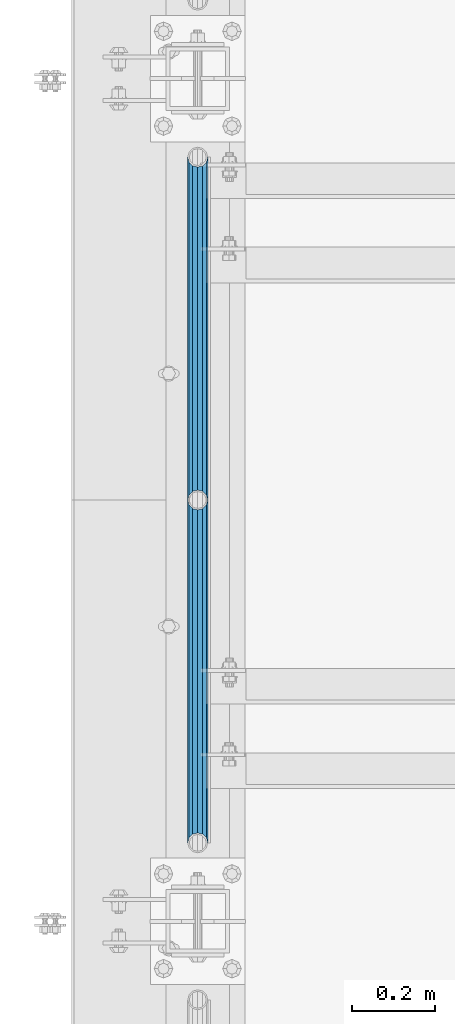
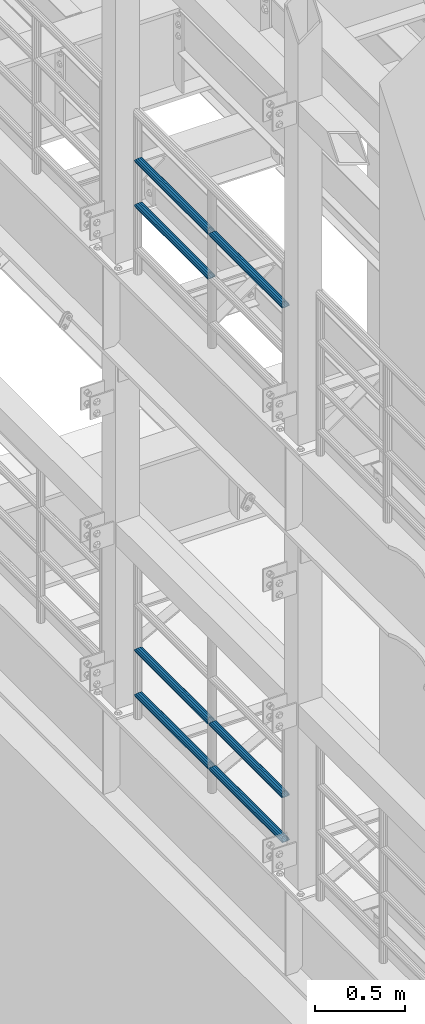
# One storey, part 1253 of 1876: 7 beams, 2 elements without a shape of their own.
"""IFC2X3 building model written with IfcOpenShell, lengths in millimetres."""

from ifc_helpers import new_model, si_unit, frame, origin_with_axes, place, context, subcontext, project, spatial, faceted_brep, material, type_object, element, aggregate, save


model = new_model("IFC2X3")

# Units and contexts
model_context = context("Model", 3, precision=1e-05, world=origin_with_axes())
body_context = subcontext(model_context, "Body", "Model", "MODEL_VIEW")
ifc_project = project(units=[si_unit("LENGTHUNIT", "METRE", prefix="MILLI"), si_unit("AREAUNIT", "SQUARE_METRE"), si_unit("VOLUMEUNIT", "CUBIC_METRE"), si_unit("MASSUNIT", "GRAM", prefix="KILO"), si_unit("TIMEUNIT", "SECOND"), si_unit("PLANEANGLEUNIT", "RADIAN"), si_unit("SOLIDANGLEUNIT", "STERADIAN"), si_unit("THERMODYNAMICTEMPERATUREUNIT", "DEGREE_CELSIUS"), si_unit("LUMINOUSINTENSITYUNIT", "LUMEN")], contexts=[model_context])

# Site, building, storey
site_placement = place(None, origin_with_axes())
site = spatial("IfcSite", under=ifc_project, at=site_placement, CompositionType="ELEMENT")
building_placement = place(site_placement, origin_with_axes())
building = spatial("IfcBuilding", under=site, at=building_placement, Name="Undefined", CompositionType="ELEMENT")
storey_placement = place(building_placement, origin_with_axes())
storey = spatial("IfcBuildingStorey", under=building, at=storey_placement, Name="Undefined", CompositionType="ELEMENT", Elevation=0.0)

# Assembly, beams
assembly_1_placement = place(storey_placement, origin_with_axes())
assembly_1 = element("IfcElementAssembly", 1, at=assembly_1_placement, inside=storey, Name="RAIL", AssemblyPlace="NOTDEFINED", PredefinedType="RIGID_FRAME")
ifc_material = material()
beam_type = type_object("IfcBeamType", Name="PIPE1-1/2SCH40", PredefinedType="NOTDEFINED")
beam_1_placement = place(assembly_1_placement, frame((-1.81898940354586e-12, 4572.0, 8620.125), z_axis=(0.0, 0.0, -1.0), x_axis=(0.0, 1.0, 0.0)))
beam_1 = element("IfcBeam", 2, at=beam_1_placement, type_object=beam_type, material=ifc_material, Name="RAIL", ObjectType="PIPE1-1/2SCH40", context=body_context, shape_type="Brep", body=[
    faceted_brep([(0.0, 24.1299999999992, 0.0), (12.0650000000064, 20.8971929933177, -12.0649999999987), (12.0650000000064, 20.8971929933177, 12.0649999999987), (12.0650000000064, -20.8971929933177, 12.0649999999987), (12.0650000000064, -20.8971929933177, -12.0649999999987), (0.0, -24.1299999999992, 0.0), (20.8971929933249, -12.0650000000005, 20.8971929933177), (20.8971929933249, -12.0650000000005, 15.8661214311796), (15.2545715621445, -17.7076214311801, 10.2235000000001), (12.5151929933249, -20.4470000000001, 0.0), (15.2545715621445, -17.7076214311801, -10.2235000000001), (20.8971929933249, -12.0650000000005, -15.8661214311796), (20.8971929933249, -12.0650000000005, -20.8971929933177), (24.1300000000063, 0.0, -20.4470000000001), (24.1300000000063, 0.0, -24.130000000001), (21.3906214311868, -10.2235000000001, -17.7076214311819), (21.3906214311868, 10.2235000000001, -17.7076214311819), (20.8971929933249, 12.0650000000005, -15.8661214311796), (20.8971929933249, 12.0650000000005, -20.8971929933177), (15.2545715621445, 17.7076214311801, -10.2235000000001), (12.5151929933249, 20.4470000000001, 0.0), (15.2545715621445, 17.7076214311801, 10.2235000000001), (20.8971929933249, 12.0650000000005, 15.8661214311796), (20.8971929933249, 12.0650000000005, 20.8971929933177), (21.3906214311868, 10.2235000000001, 17.7076214311819), (24.1300000000064, 0.0, 20.4470000000001), (24.1300000000064, 0.0, 24.130000000001), (21.3906214311868, -10.2235000000001, 17.7076214311819), (826.77, 24.1300000000001, 0.0), (814.705, 20.8971929933186, -12.0649999999987), (805.872807006681, 12.0649999999996, -20.8971929933177), (826.77, -24.1300000000001, 0.0), (814.705, -20.8971929933186, -12.0649999999987), (814.705, -20.8971929933186, 12.0649999999987), (805.872807006681, -12.0649999999996, 20.8971929933177), (805.872807006681, -12.0649999999996, -20.8971929933177), (802.640000000001, 0.0, -24.130000000001), (805.379378568819, 10.2235000000001, -17.7076214311819), (802.640000000001, 0.0, -20.4470000000001), (805.872807006683, 12.0649999999996, -15.8661214311796), (805.872807006683, -12.0649999999996, -15.8661214311796), (805.379378568819, -10.2235000000001, -17.7076214311819), (811.515428437862, -17.7076214311801, -10.2235000000001), (814.254807006682, -20.4470000000001, 0.0), (811.515428437862, -17.7076214311801, 10.2235000000001), (805.872807006683, -12.0649999999996, 15.8661214311796), (805.379378568819, -10.2235000000001, 17.7076214311819), (802.640000000001, 0.0, 20.4470000000001), (802.640000000001, 0.0, 24.130000000001), (805.872807006681, 12.0649999999996, 20.8971929933177), (814.705, 20.8971929933186, 12.0649999999987), (805.872807006683, 12.0649999999996, 15.8661214311796), (811.515428437862, 17.7076214311801, 10.2235000000001), (814.254807006682, 20.4470000000001, 0.0), (811.515428437862, 17.7076214311801, -10.2235000000001), (805.379378568819, 10.2235000000001, 17.7076214311819)], [[[0, 1, 2]], [[3, 4, 5]], [[6, 7, 8, 9, 10, 11, 12, 4, 3]], [[13, 14, 12, 11, 15]], [[16, 17, 18, 14, 13]], [[2, 1, 18, 17, 19, 20, 21, 22, 23]], [[23, 22, 24, 25, 26]], [[26, 25, 27, 7, 6]], [[1, 0, 28, 29]], [[18, 1, 29, 30]], [[31, 32, 33]], [[6, 3, 33, 34]], [[3, 5, 31, 33]], [[5, 4, 32, 31]], [[4, 12, 35, 32]], [[12, 14, 36, 35]], [[14, 18, 30, 36]], [[37, 38, 36, 30, 39]], [[40, 35, 36, 38, 41]], [[33, 32, 35, 40, 42, 43, 44, 45, 34]], [[34, 45, 46, 47, 48]], [[26, 6, 34, 48]], [[2, 23, 49, 50]], [[23, 26, 48, 49]], [[0, 2, 50, 28]], [[28, 50, 29]], [[49, 51, 52, 53, 54, 39, 30, 29, 50]], [[48, 47, 55, 51, 49]], [[25, 24, 55, 47]], [[55, 24, 22, 21, 52, 51]], [[21, 20, 53, 52]], [[20, 19, 54, 53]], [[19, 17, 16, 37, 39, 54]], [[16, 13, 38, 37]], [[13, 15, 41, 38]], [[41, 15, 11, 10, 42, 40]], [[10, 9, 43, 42]], [[9, 8, 44, 43]], [[8, 7, 27, 46, 45, 44]], [[27, 25, 47, 46]]]),
])
beam_2_placement = place(assembly_1_placement, frame((-1.81898940354586e-12, 3745.23, 8924.925), z_axis=(0.0, 0.0, -1.0), x_axis=(0.0, 1.0, 0.0)))
beam_2 = element("IfcBeam", 3, at=beam_2_placement, type_object=beam_type, material=ifc_material, Name="RAIL", ObjectType="PIPE1-1/2SCH40", context=body_context, shape_type="Brep", body=[
    faceted_brep([(0.0, 24.1299999999992, 0.0), (12.0650000000064, 20.8971929933177, -12.0649999999987), (12.0650000000064, 20.8971929933177, 12.0649999999987), (12.0650000000064, -20.8971929933177, 12.0649999999987), (12.0650000000064, -20.8971929933177, -12.0649999999987), (0.0, -24.1299999999992, 0.0), (20.8971929933249, -12.0650000000005, 20.8971929933177), (20.8971929933249, -12.0650000000005, 15.8661214311796), (15.2545715621445, -17.7076214311801, 10.2235000000001), (12.5151929933249, -20.4470000000001, 0.0), (15.2545715621445, -17.7076214311801, -10.2235000000001), (20.8971929933249, -12.0650000000005, -15.8661214311796), (20.8971929933249, -12.0650000000005, -20.8971929933177), (24.1300000000063, 0.0, -20.4470000000001), (24.1300000000063, 0.0, -24.130000000001), (21.3906214311868, -10.2235000000001, -17.7076214311819), (21.3906214311868, 10.2235000000001, -17.7076214311819), (20.8971929933249, 12.0650000000005, -15.8661214311796), (20.8971929933249, 12.0650000000005, -20.8971929933177), (15.2545715621445, 17.7076214311801, -10.2235000000001), (12.5151929933249, 20.4470000000001, 0.0), (15.2545715621445, 17.7076214311801, 10.2235000000001), (20.8971929933249, 12.0650000000005, 15.8661214311796), (20.8971929933249, 12.0650000000005, 20.8971929933177), (21.3906214311868, 10.2235000000001, 17.7076214311819), (24.1300000000064, 0.0, 20.4470000000001), (24.1300000000064, 0.0, 24.130000000001), (21.3906214311868, -10.2235000000001, 17.7076214311819), (826.77, 24.1300000000001, 0.0), (814.705, 20.8971929933186, -12.0649999999987), (805.872807006681, 12.0649999999996, -20.8971929933177), (826.77, -24.1300000000001, 0.0), (814.705, -20.8971929933186, -12.0649999999987), (814.705, -20.8971929933186, 12.0649999999987), (805.872807006681, -12.0649999999996, 20.8971929933177), (805.872807006681, -12.0649999999996, -20.8971929933177), (802.640000000001, 0.0, -24.130000000001), (805.379378568819, 10.2235000000001, -17.7076214311819), (802.640000000001, 0.0, -20.4470000000001), (805.872807006683, 12.0649999999996, -15.8661214311796), (805.872807006683, -12.0649999999996, -15.8661214311796), (805.379378568819, -10.2235000000001, -17.7076214311819), (811.515428437862, -17.7076214311801, -10.2235000000001), (814.254807006682, -20.4470000000001, 0.0), (811.515428437862, -17.7076214311801, 10.2235000000001), (805.872807006683, -12.0649999999996, 15.8661214311796), (805.379378568819, -10.2235000000001, 17.7076214311819), (802.640000000001, 0.0, 20.4470000000001), (802.640000000001, 0.0, 24.130000000001), (805.872807006681, 12.0649999999996, 20.8971929933177), (814.705, 20.8971929933186, 12.0649999999987), (805.872807006683, 12.0649999999996, 15.8661214311796), (811.515428437862, 17.7076214311801, 10.2235000000001), (814.254807006682, 20.4470000000001, 0.0), (811.515428437862, 17.7076214311801, -10.2235000000001), (805.379378568819, 10.2235000000001, 17.7076214311819)], [[[0, 1, 2]], [[3, 4, 5]], [[6, 7, 8, 9, 10, 11, 12, 4, 3]], [[13, 14, 12, 11, 15]], [[16, 17, 18, 14, 13]], [[2, 1, 18, 17, 19, 20, 21, 22, 23]], [[23, 22, 24, 25, 26]], [[26, 25, 27, 7, 6]], [[1, 0, 28, 29]], [[18, 1, 29, 30]], [[31, 32, 33]], [[6, 3, 33, 34]], [[3, 5, 31, 33]], [[5, 4, 32, 31]], [[4, 12, 35, 32]], [[12, 14, 36, 35]], [[14, 18, 30, 36]], [[37, 38, 36, 30, 39]], [[40, 35, 36, 38, 41]], [[33, 32, 35, 40, 42, 43, 44, 45, 34]], [[34, 45, 46, 47, 48]], [[26, 6, 34, 48]], [[2, 23, 49, 50]], [[23, 26, 48, 49]], [[0, 2, 50, 28]], [[28, 50, 29]], [[49, 51, 52, 53, 54, 39, 30, 29, 50]], [[48, 47, 55, 51, 49]], [[25, 24, 55, 47]], [[55, 24, 22, 21, 52, 51]], [[21, 20, 53, 52]], [[20, 19, 54, 53]], [[19, 17, 16, 37, 39, 54]], [[16, 13, 38, 37]], [[13, 15, 41, 38]], [[41, 15, 11, 10, 42, 40]], [[10, 9, 43, 42]], [[9, 8, 44, 43]], [[8, 7, 27, 46, 45, 44]], [[27, 25, 47, 46]]]),
])
beam_3_placement = place(assembly_1_placement, frame((-1.81898940354586e-12, 4572.0, 8924.925), z_axis=(0.0, 0.0, -1.0), x_axis=(0.0, 1.0, 0.0)))
beam_3 = element("IfcBeam", 4, at=beam_3_placement, type_object=beam_type, material=ifc_material, Name="RAIL", ObjectType="PIPE1-1/2SCH40", context=body_context, shape_type="Brep", body=[
    faceted_brep([(0.0, 24.1299999999992, 0.0), (12.0650000000064, 20.8971929933177, -12.0649999999987), (12.0650000000064, 20.8971929933177, 12.0649999999987), (12.0650000000064, -20.8971929933177, 12.0649999999987), (12.0650000000064, -20.8971929933177, -12.0649999999987), (0.0, -24.1299999999992, 0.0), (20.8971929933249, -12.0650000000005, 20.8971929933177), (20.8971929933249, -12.0650000000005, 15.8661214311796), (15.2545715621445, -17.7076214311801, 10.2235000000001), (12.5151929933249, -20.4470000000001, 0.0), (15.2545715621445, -17.7076214311801, -10.2235000000001), (20.8971929933249, -12.0650000000005, -15.8661214311796), (20.8971929933249, -12.0650000000005, -20.8971929933177), (24.1300000000063, 0.0, -20.4470000000001), (24.1300000000063, 0.0, -24.130000000001), (21.3906214311868, -10.2235000000001, -17.7076214311819), (21.3906214311868, 10.2235000000001, -17.7076214311819), (20.8971929933249, 12.0650000000005, -15.8661214311796), (20.8971929933249, 12.0650000000005, -20.8971929933177), (15.2545715621445, 17.7076214311801, -10.2235000000001), (12.5151929933249, 20.4470000000001, 0.0), (15.2545715621445, 17.7076214311801, 10.2235000000001), (20.8971929933249, 12.0650000000005, 15.8661214311796), (20.8971929933249, 12.0650000000005, 20.8971929933177), (21.3906214311868, 10.2235000000001, 17.7076214311819), (24.1300000000064, 0.0, 20.4470000000001), (24.1300000000064, 0.0, 24.130000000001), (21.3906214311868, -10.2235000000001, 17.7076214311819), (826.77, 24.1300000000001, 0.0), (814.705, 20.8971929933186, -12.0649999999987), (805.872807006681, 12.0649999999996, -20.8971929933177), (826.77, -24.1300000000001, 0.0), (814.705, -20.8971929933186, -12.0649999999987), (814.705, -20.8971929933186, 12.0649999999987), (805.872807006681, -12.0649999999996, 20.8971929933177), (805.872807006681, -12.0649999999996, -20.8971929933177), (802.640000000001, 0.0, -24.130000000001), (805.379378568819, 10.2235000000001, -17.7076214311819), (802.640000000001, 0.0, -20.4470000000001), (805.872807006683, 12.0649999999996, -15.8661214311796), (805.872807006683, -12.0649999999996, -15.8661214311796), (805.379378568819, -10.2235000000001, -17.7076214311819), (811.515428437862, -17.7076214311801, -10.2235000000001), (814.254807006682, -20.4470000000001, 0.0), (811.515428437862, -17.7076214311801, 10.2235000000001), (805.872807006683, -12.0649999999996, 15.8661214311796), (805.379378568819, -10.2235000000001, 17.7076214311819), (802.640000000001, 0.0, 20.4470000000001), (802.640000000001, 0.0, 24.130000000001), (805.872807006681, 12.0649999999996, 20.8971929933177), (814.705, 20.8971929933186, 12.0649999999987), (805.872807006683, 12.0649999999996, 15.8661214311796), (811.515428437862, 17.7076214311801, 10.2235000000001), (814.254807006682, 20.4470000000001, 0.0), (811.515428437862, 17.7076214311801, -10.2235000000001), (805.379378568819, 10.2235000000001, 17.7076214311819)], [[[0, 1, 2]], [[3, 4, 5]], [[6, 7, 8, 9, 10, 11, 12, 4, 3]], [[13, 14, 12, 11, 15]], [[16, 17, 18, 14, 13]], [[2, 1, 18, 17, 19, 20, 21, 22, 23]], [[23, 22, 24, 25, 26]], [[26, 25, 27, 7, 6]], [[1, 0, 28, 29]], [[18, 1, 29, 30]], [[31, 32, 33]], [[6, 3, 33, 34]], [[3, 5, 31, 33]], [[5, 4, 32, 31]], [[4, 12, 35, 32]], [[12, 14, 36, 35]], [[14, 18, 30, 36]], [[37, 38, 36, 30, 39]], [[40, 35, 36, 38, 41]], [[33, 32, 35, 40, 42, 43, 44, 45, 34]], [[34, 45, 46, 47, 48]], [[26, 6, 34, 48]], [[2, 23, 49, 50]], [[23, 26, 48, 49]], [[0, 2, 50, 28]], [[28, 50, 29]], [[49, 51, 52, 53, 54, 39, 30, 29, 50]], [[48, 47, 55, 51, 49]], [[25, 24, 55, 47]], [[55, 24, 22, 21, 52, 51]], [[21, 20, 53, 52]], [[20, 19, 54, 53]], [[19, 17, 16, 37, 39, 54]], [[16, 13, 38, 37]], [[13, 15, 41, 38]], [[41, 15, 11, 10, 42, 40]], [[10, 9, 43, 42]], [[9, 8, 44, 43]], [[8, 7, 27, 46, 45, 44]], [[27, 25, 47, 46]]]),
])
aggregate(assembly_1, [beam_1, beam_2, beam_3])

assembly_2_placement = place(storey_placement, origin_with_axes())
assembly_2 = element("IfcElementAssembly", 5, at=assembly_2_placement, inside=storey, Name="RAIL", AssemblyPlace="NOTDEFINED", PredefinedType="RIGID_FRAME")
beam_4_placement = place(assembly_2_placement, frame((-1.81898940354586e-12, 4572.0, 5292.725), z_axis=(0.0, 0.0, 1.0), x_axis=(0.0, -1.0, 0.0)))
beam_4 = element("IfcBeam", 6, at=beam_4_placement, type_object=beam_type, material=ifc_material, Name="RAIL", ObjectType="PIPE1-1/2SCH40", context=body_context, shape_type="Brep", body=[
    faceted_brep([(805.872807006681, -12.0649999999996, 20.8971929933177), (805.872807006683, -12.0649999999996, 15.8661214311796), (805.379378568819, -10.2235000000001, 17.7076214311819), (802.640000000001, 0.0, 20.4470000000001), (802.640000000001, 0.0, 24.130000000001), (805.379378568819, 10.2235000000001, 17.7076214311819), (805.872807006683, 12.0649999999996, 15.8661214311796), (805.872807006681, 12.0649999999996, 20.8971929933177), (826.77, 24.1300000000001, 0.0), (814.705, 20.8971929933186, 12.0649999999987), (814.705, 20.8971929933186, -12.0649999999987), (811.515428437862, 17.7076214311801, 10.2235000000001), (814.254807006682, 20.4470000000001, 0.0), (811.515428437862, 17.7076214311801, -10.2235000000001), (805.872807006683, 12.0649999999996, -15.8661214311796), (805.872807006681, 12.0649999999996, -20.8971929933177), (805.379378568819, 10.2235000000001, -17.7076214311819), (802.640000000001, 0.0, -20.4470000000001), (802.640000000001, 0.0, -24.130000000001), (805.872807006683, -12.0649999999996, -15.8661214311796), (805.872807006681, -12.0649999999996, -20.8971929933177), (805.379378568819, -10.2235000000001, -17.7076214311819), (826.77, -24.1300000000001, 0.0), (814.705, -20.8971929933186, -12.0649999999987), (814.705, -20.8971929933186, 12.0649999999987), (811.515428437862, -17.7076214311801, -10.2235000000001), (814.254807006682, -20.4470000000001, 0.0), (811.515428437862, -17.7076214311801, 10.2235000000001), (12.0650000000064, -20.8971929933177, -12.0649999999987), (20.8971929933249, -12.0650000000005, -20.8971929933177), (0.0, 24.1299999999992, 0.0), (12.0650000000064, 20.8971929933177, -12.0649999999987), (12.0650000000064, 20.8971929933177, 12.0649999999987), (20.8971929933249, 12.0650000000005, 20.8971929933177), (24.1300000000064, 0.0, 24.130000000001), (20.8971929933249, 12.0650000000005, -20.8971929933177), (24.1300000000063, 0.0, -24.130000000001), (24.1300000000063, 0.0, -20.4470000000001), (20.8971929933249, -12.0650000000005, -15.8661214311796), (21.3906214311868, -10.2235000000001, -17.7076214311819), (21.3906214311868, 10.2235000000001, -17.7076214311819), (20.8971929933249, 12.0650000000005, -15.8661214311796), (15.2545715621445, 17.7076214311801, -10.2235000000001), (12.5151929933249, 20.4470000000001, 0.0), (15.2545715621445, 17.7076214311801, 10.2235000000001), (20.8971929933249, 12.0650000000005, 15.8661214311796), (21.3906214311868, 10.2235000000001, 17.7076214311819), (24.1300000000064, 0.0, 20.4470000000001), (21.3906214311868, -10.2235000000001, 17.7076214311819), (20.8971929933249, -12.0650000000005, 15.8661214311796), (20.8971929933249, -12.0650000000005, 20.8971929933177), (12.0650000000064, -20.8971929933177, 12.0649999999987), (0.0, -24.1299999999992, 0.0), (15.2545715621445, -17.7076214311801, 10.2235000000001), (12.5151929933249, -20.4470000000001, 0.0), (15.2545715621445, -17.7076214311801, -10.2235000000001)], [[[0, 1, 2, 3, 4]], [[4, 3, 5, 6, 7]], [[8, 9, 10]], [[7, 6, 11, 12, 13, 14, 15, 10, 9]], [[16, 17, 18, 15, 14]], [[19, 20, 18, 17, 21]], [[22, 23, 24]], [[24, 23, 20, 19, 25, 26, 27, 1, 0]], [[28, 29, 20, 23]], [[30, 31, 32]], [[33, 34, 4, 7]], [[32, 33, 7, 9]], [[30, 32, 9, 8]], [[31, 30, 8, 10]], [[35, 31, 10, 15]], [[36, 35, 15, 18]], [[29, 36, 18, 20]], [[37, 36, 29, 38, 39]], [[40, 41, 35, 36, 37]], [[32, 31, 35, 41, 42, 43, 44, 45, 33]], [[33, 45, 46, 47, 34]], [[34, 47, 48, 49, 50]], [[34, 50, 0, 4]], [[50, 51, 24, 0]], [[51, 52, 22, 24]], [[52, 28, 23, 22]], [[51, 28, 52]], [[50, 49, 53, 54, 55, 38, 29, 28, 51]], [[55, 54, 26, 25]], [[21, 39, 38, 55, 25, 19]], [[37, 39, 21, 17]], [[40, 37, 17, 16]], [[42, 41, 40, 16, 14, 13]], [[43, 42, 13, 12]], [[44, 43, 12, 11]], [[5, 46, 45, 44, 11, 6]], [[47, 46, 5, 3]], [[48, 47, 3, 2]], [[53, 49, 48, 2, 1, 27]], [[54, 53, 27, 26]]]),
])
beam_5_placement = place(assembly_2_placement, frame((-1.81898940354586e-12, 5398.77, 5292.725), z_axis=(0.0, 0.0, 1.0), x_axis=(0.0, -1.0, 0.0)))
beam_5 = element("IfcBeam", 7, at=beam_5_placement, type_object=beam_type, material=ifc_material, Name="RAIL", ObjectType="PIPE1-1/2SCH40", context=body_context, shape_type="Brep", body=[
    faceted_brep([(805.872807006681, -12.0649999999996, 20.8971929933177), (805.872807006683, -12.0649999999996, 15.8661214311796), (805.379378568819, -10.2235000000001, 17.7076214311819), (802.640000000001, 0.0, 20.4470000000001), (802.640000000001, 0.0, 24.130000000001), (805.379378568819, 10.2235000000001, 17.7076214311819), (805.872807006683, 12.0649999999996, 15.8661214311796), (805.872807006681, 12.0649999999996, 20.8971929933177), (826.77, 24.1300000000001, 0.0), (814.705, 20.8971929933186, 12.0649999999987), (814.705, 20.8971929933186, -12.0649999999987), (811.515428437862, 17.7076214311801, 10.2235000000001), (814.254807006682, 20.4470000000001, 0.0), (811.515428437862, 17.7076214311801, -10.2235000000001), (805.872807006683, 12.0649999999996, -15.8661214311796), (805.872807006681, 12.0649999999996, -20.8971929933177), (805.379378568819, 10.2235000000001, -17.7076214311819), (802.640000000001, 0.0, -20.4470000000001), (802.640000000001, 0.0, -24.130000000001), (805.872807006683, -12.0649999999996, -15.8661214311796), (805.872807006681, -12.0649999999996, -20.8971929933177), (805.379378568819, -10.2235000000001, -17.7076214311819), (826.77, -24.1300000000001, 0.0), (814.705, -20.8971929933186, -12.0649999999987), (814.705, -20.8971929933186, 12.0649999999987), (811.515428437862, -17.7076214311801, -10.2235000000001), (814.254807006682, -20.4470000000001, 0.0), (811.515428437862, -17.7076214311801, 10.2235000000001), (12.0650000000064, -20.8971929933177, -12.0649999999987), (20.8971929933249, -12.0650000000005, -20.8971929933177), (0.0, 24.1299999999992, 0.0), (12.0650000000064, 20.8971929933177, -12.0649999999987), (12.0650000000064, 20.8971929933177, 12.0649999999987), (20.8971929933249, 12.0650000000005, 20.8971929933177), (24.1300000000064, 0.0, 24.130000000001), (20.8971929933249, 12.0650000000005, -20.8971929933177), (24.1300000000063, 0.0, -24.130000000001), (24.1300000000063, 0.0, -20.4470000000001), (20.8971929933249, -12.0650000000005, -15.8661214311796), (21.3906214311868, -10.2235000000001, -17.7076214311819), (21.3906214311868, 10.2235000000001, -17.7076214311819), (20.8971929933249, 12.0650000000005, -15.8661214311796), (15.2545715621445, 17.7076214311801, -10.2235000000001), (12.5151929933249, 20.4470000000001, 0.0), (15.2545715621445, 17.7076214311801, 10.2235000000001), (20.8971929933249, 12.0650000000005, 15.8661214311796), (21.3906214311868, 10.2235000000001, 17.7076214311819), (24.1300000000064, 0.0, 20.4470000000001), (21.3906214311868, -10.2235000000001, 17.7076214311819), (20.8971929933249, -12.0650000000005, 15.8661214311796), (20.8971929933249, -12.0650000000005, 20.8971929933177), (12.0650000000064, -20.8971929933177, 12.0649999999987), (0.0, -24.1299999999992, 0.0), (15.2545715621445, -17.7076214311801, 10.2235000000001), (12.5151929933249, -20.4470000000001, 0.0), (15.2545715621445, -17.7076214311801, -10.2235000000001)], [[[0, 1, 2, 3, 4]], [[4, 3, 5, 6, 7]], [[8, 9, 10]], [[7, 6, 11, 12, 13, 14, 15, 10, 9]], [[16, 17, 18, 15, 14]], [[19, 20, 18, 17, 21]], [[22, 23, 24]], [[24, 23, 20, 19, 25, 26, 27, 1, 0]], [[28, 29, 20, 23]], [[30, 31, 32]], [[33, 34, 4, 7]], [[32, 33, 7, 9]], [[30, 32, 9, 8]], [[31, 30, 8, 10]], [[35, 31, 10, 15]], [[36, 35, 15, 18]], [[29, 36, 18, 20]], [[37, 36, 29, 38, 39]], [[40, 41, 35, 36, 37]], [[32, 31, 35, 41, 42, 43, 44, 45, 33]], [[33, 45, 46, 47, 34]], [[34, 47, 48, 49, 50]], [[34, 50, 0, 4]], [[50, 51, 24, 0]], [[51, 52, 22, 24]], [[52, 28, 23, 22]], [[51, 28, 52]], [[50, 49, 53, 54, 55, 38, 29, 28, 51]], [[55, 54, 26, 25]], [[21, 39, 38, 55, 25, 19]], [[37, 39, 21, 17]], [[40, 37, 17, 16]], [[42, 41, 40, 16, 14, 13]], [[43, 42, 13, 12]], [[44, 43, 12, 11]], [[5, 46, 45, 44, 11, 6]], [[47, 46, 5, 3]], [[48, 47, 3, 2]], [[53, 49, 48, 2, 1, 27]], [[54, 53, 27, 26]]]),
])
beam_6_placement = place(assembly_2_placement, frame((-1.81898940354586e-12, 3745.23, 5597.525), z_axis=(0.0, 0.0, -1.0), x_axis=(0.0, 1.0, 0.0)))
beam_6 = element("IfcBeam", 8, at=beam_6_placement, type_object=beam_type, material=ifc_material, Name="RAIL", ObjectType="PIPE1-1/2SCH40", context=body_context, shape_type="Brep", body=[
    faceted_brep([(0.0, 24.1299999999992, 0.0), (12.0650000000064, 20.8971929933177, -12.0649999999987), (12.0650000000064, 20.8971929933177, 12.0649999999987), (12.0650000000064, -20.8971929933177, 12.0649999999987), (12.0650000000064, -20.8971929933177, -12.0649999999987), (0.0, -24.1299999999992, 0.0), (20.8971929933249, -12.0650000000005, 20.8971929933177), (20.8971929933249, -12.0650000000005, 15.8661214311796), (15.2545715621445, -17.7076214311801, 10.2235000000001), (12.5151929933249, -20.4470000000001, 0.0), (15.2545715621445, -17.7076214311801, -10.2235000000001), (20.8971929933249, -12.0650000000005, -15.8661214311796), (20.8971929933249, -12.0650000000005, -20.8971929933177), (24.1300000000063, 0.0, -20.4470000000001), (24.1300000000063, 0.0, -24.130000000001), (21.3906214311868, -10.2235000000001, -17.7076214311819), (21.3906214311868, 10.2235000000001, -17.7076214311819), (20.8971929933249, 12.0650000000005, -15.8661214311796), (20.8971929933249, 12.0650000000005, -20.8971929933177), (15.2545715621445, 17.7076214311801, -10.2235000000001), (12.5151929933249, 20.4470000000001, 0.0), (15.2545715621445, 17.7076214311801, 10.2235000000001), (20.8971929933249, 12.0650000000005, 15.8661214311796), (20.8971929933249, 12.0650000000005, 20.8971929933177), (21.3906214311868, 10.2235000000001, 17.7076214311819), (24.1300000000064, 0.0, 20.4470000000001), (24.1300000000064, 0.0, 24.130000000001), (21.3906214311868, -10.2235000000001, 17.7076214311819), (826.77, 24.1300000000001, 0.0), (814.705, 20.8971929933186, -12.0649999999987), (805.872807006681, 12.0649999999996, -20.8971929933177), (826.77, -24.1300000000001, 0.0), (814.705, -20.8971929933186, -12.0649999999987), (814.705, -20.8971929933186, 12.0649999999987), (805.872807006681, -12.0649999999996, 20.8971929933177), (805.872807006681, -12.0649999999996, -20.8971929933177), (802.640000000001, 0.0, -24.130000000001), (805.379378568819, 10.2235000000001, -17.7076214311819), (802.640000000001, 0.0, -20.4470000000001), (805.872807006683, 12.0649999999996, -15.8661214311796), (805.872807006683, -12.0649999999996, -15.8661214311796), (805.379378568819, -10.2235000000001, -17.7076214311819), (811.515428437862, -17.7076214311801, -10.2235000000001), (814.254807006682, -20.4470000000001, 0.0), (811.515428437862, -17.7076214311801, 10.2235000000001), (805.872807006683, -12.0649999999996, 15.8661214311796), (805.379378568819, -10.2235000000001, 17.7076214311819), (802.640000000001, 0.0, 20.4470000000001), (802.640000000001, 0.0, 24.130000000001), (805.872807006681, 12.0649999999996, 20.8971929933177), (814.705, 20.8971929933186, 12.0649999999987), (805.872807006683, 12.0649999999996, 15.8661214311796), (811.515428437862, 17.7076214311801, 10.2235000000001), (814.254807006682, 20.4470000000001, 0.0), (811.515428437862, 17.7076214311801, -10.2235000000001), (805.379378568819, 10.2235000000001, 17.7076214311819)], [[[0, 1, 2]], [[3, 4, 5]], [[6, 7, 8, 9, 10, 11, 12, 4, 3]], [[13, 14, 12, 11, 15]], [[16, 17, 18, 14, 13]], [[2, 1, 18, 17, 19, 20, 21, 22, 23]], [[23, 22, 24, 25, 26]], [[26, 25, 27, 7, 6]], [[1, 0, 28, 29]], [[18, 1, 29, 30]], [[31, 32, 33]], [[6, 3, 33, 34]], [[3, 5, 31, 33]], [[5, 4, 32, 31]], [[4, 12, 35, 32]], [[12, 14, 36, 35]], [[14, 18, 30, 36]], [[37, 38, 36, 30, 39]], [[40, 35, 36, 38, 41]], [[33, 32, 35, 40, 42, 43, 44, 45, 34]], [[34, 45, 46, 47, 48]], [[26, 6, 34, 48]], [[2, 23, 49, 50]], [[23, 26, 48, 49]], [[0, 2, 50, 28]], [[28, 50, 29]], [[49, 51, 52, 53, 54, 39, 30, 29, 50]], [[48, 47, 55, 51, 49]], [[25, 24, 55, 47]], [[55, 24, 22, 21, 52, 51]], [[21, 20, 53, 52]], [[20, 19, 54, 53]], [[19, 17, 16, 37, 39, 54]], [[16, 13, 38, 37]], [[13, 15, 41, 38]], [[41, 15, 11, 10, 42, 40]], [[10, 9, 43, 42]], [[9, 8, 44, 43]], [[8, 7, 27, 46, 45, 44]], [[27, 25, 47, 46]]]),
])
beam_7_placement = place(assembly_2_placement, frame((-1.81898940354586e-12, 4572.0, 5597.525), z_axis=(0.0, 0.0, -1.0), x_axis=(0.0, 1.0, 0.0)))
beam_7 = element("IfcBeam", 9, at=beam_7_placement, type_object=beam_type, material=ifc_material, Name="RAIL", ObjectType="PIPE1-1/2SCH40", context=body_context, shape_type="Brep", body=[
    faceted_brep([(0.0, 24.1299999999992, 0.0), (12.0650000000064, 20.8971929933177, -12.0649999999987), (12.0650000000064, 20.8971929933177, 12.0649999999987), (12.0650000000064, -20.8971929933177, 12.0649999999987), (12.0650000000064, -20.8971929933177, -12.0649999999987), (0.0, -24.1299999999992, 0.0), (20.8971929933249, -12.0650000000005, 20.8971929933177), (20.8971929933249, -12.0650000000005, 15.8661214311796), (15.2545715621445, -17.7076214311801, 10.2235000000001), (12.5151929933249, -20.4470000000001, 0.0), (15.2545715621445, -17.7076214311801, -10.2235000000001), (20.8971929933249, -12.0650000000005, -15.8661214311796), (20.8971929933249, -12.0650000000005, -20.8971929933177), (24.1300000000063, 0.0, -20.4470000000001), (24.1300000000063, 0.0, -24.130000000001), (21.3906214311868, -10.2235000000001, -17.7076214311819), (21.3906214311868, 10.2235000000001, -17.7076214311819), (20.8971929933249, 12.0650000000005, -15.8661214311796), (20.8971929933249, 12.0650000000005, -20.8971929933177), (15.2545715621445, 17.7076214311801, -10.2235000000001), (12.5151929933249, 20.4470000000001, 0.0), (15.2545715621445, 17.7076214311801, 10.2235000000001), (20.8971929933249, 12.0650000000005, 15.8661214311796), (20.8971929933249, 12.0650000000005, 20.8971929933177), (21.3906214311868, 10.2235000000001, 17.7076214311819), (24.1300000000064, 0.0, 20.4470000000001), (24.1300000000064, 0.0, 24.130000000001), (21.3906214311868, -10.2235000000001, 17.7076214311819), (826.77, 24.1300000000001, 0.0), (814.705, 20.8971929933186, -12.0649999999987), (805.872807006681, 12.0649999999996, -20.8971929933177), (826.77, -24.1300000000001, 0.0), (814.705, -20.8971929933186, -12.0649999999987), (814.705, -20.8971929933186, 12.0649999999987), (805.872807006681, -12.0649999999996, 20.8971929933177), (805.872807006681, -12.0649999999996, -20.8971929933177), (802.640000000001, 0.0, -24.130000000001), (805.379378568819, 10.2235000000001, -17.7076214311819), (802.640000000001, 0.0, -20.4470000000001), (805.872807006683, 12.0649999999996, -15.8661214311796), (805.872807006683, -12.0649999999996, -15.8661214311796), (805.379378568819, -10.2235000000001, -17.7076214311819), (811.515428437862, -17.7076214311801, -10.2235000000001), (814.254807006682, -20.4470000000001, 0.0), (811.515428437862, -17.7076214311801, 10.2235000000001), (805.872807006683, -12.0649999999996, 15.8661214311796), (805.379378568819, -10.2235000000001, 17.7076214311819), (802.640000000001, 0.0, 20.4470000000001), (802.640000000001, 0.0, 24.130000000001), (805.872807006681, 12.0649999999996, 20.8971929933177), (814.705, 20.8971929933186, 12.0649999999987), (805.872807006683, 12.0649999999996, 15.8661214311796), (811.515428437862, 17.7076214311801, 10.2235000000001), (814.254807006682, 20.4470000000001, 0.0), (811.515428437862, 17.7076214311801, -10.2235000000001), (805.379378568819, 10.2235000000001, 17.7076214311819)], [[[0, 1, 2]], [[3, 4, 5]], [[6, 7, 8, 9, 10, 11, 12, 4, 3]], [[13, 14, 12, 11, 15]], [[16, 17, 18, 14, 13]], [[2, 1, 18, 17, 19, 20, 21, 22, 23]], [[23, 22, 24, 25, 26]], [[26, 25, 27, 7, 6]], [[1, 0, 28, 29]], [[18, 1, 29, 30]], [[31, 32, 33]], [[6, 3, 33, 34]], [[3, 5, 31, 33]], [[5, 4, 32, 31]], [[4, 12, 35, 32]], [[12, 14, 36, 35]], [[14, 18, 30, 36]], [[37, 38, 36, 30, 39]], [[40, 35, 36, 38, 41]], [[33, 32, 35, 40, 42, 43, 44, 45, 34]], [[34, 45, 46, 47, 48]], [[26, 6, 34, 48]], [[2, 23, 49, 50]], [[23, 26, 48, 49]], [[0, 2, 50, 28]], [[28, 50, 29]], [[49, 51, 52, 53, 54, 39, 30, 29, 50]], [[48, 47, 55, 51, 49]], [[25, 24, 55, 47]], [[55, 24, 22, 21, 52, 51]], [[21, 20, 53, 52]], [[20, 19, 54, 53]], [[19, 17, 16, 37, 39, 54]], [[16, 13, 38, 37]], [[13, 15, 41, 38]], [[41, 15, 11, 10, 42, 40]], [[10, 9, 43, 42]], [[9, 8, 44, 43]], [[8, 7, 27, 46, 45, 44]], [[27, 25, 47, 46]]]),
])
aggregate(assembly_2, [beam_4, beam_5, beam_6, beam_7])

save(model, "model.ifc")
